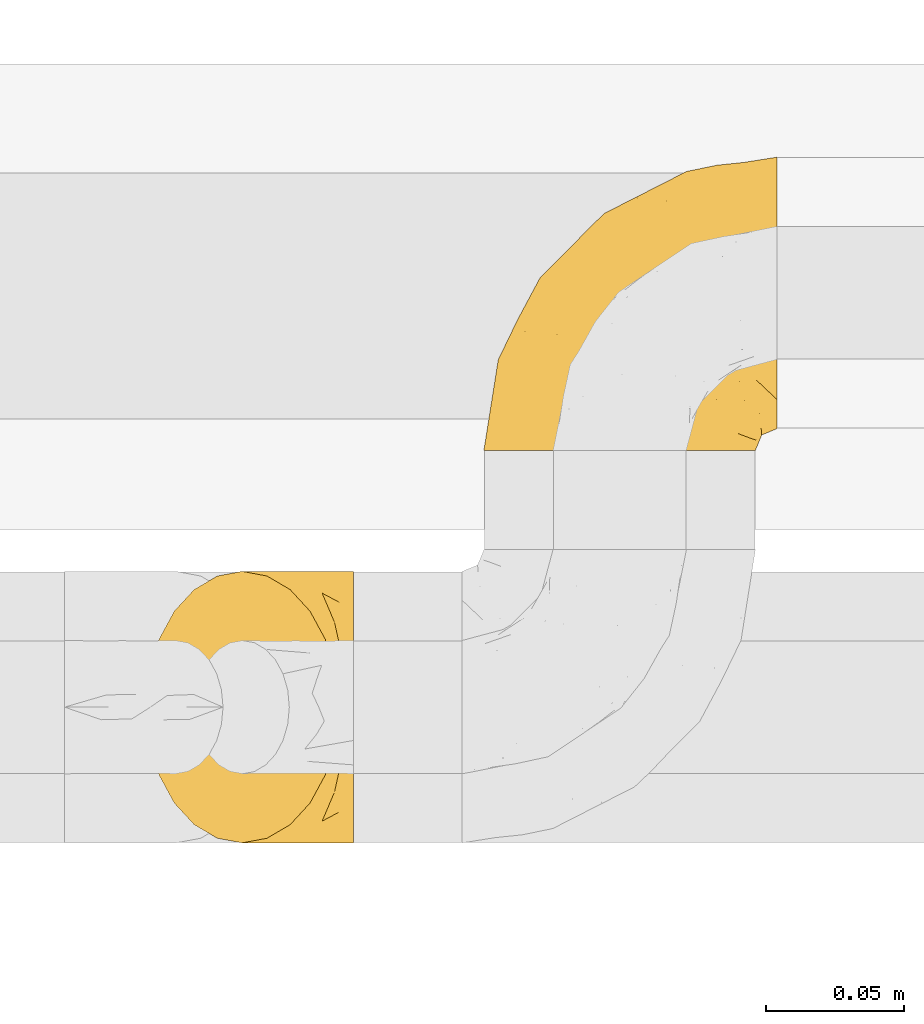
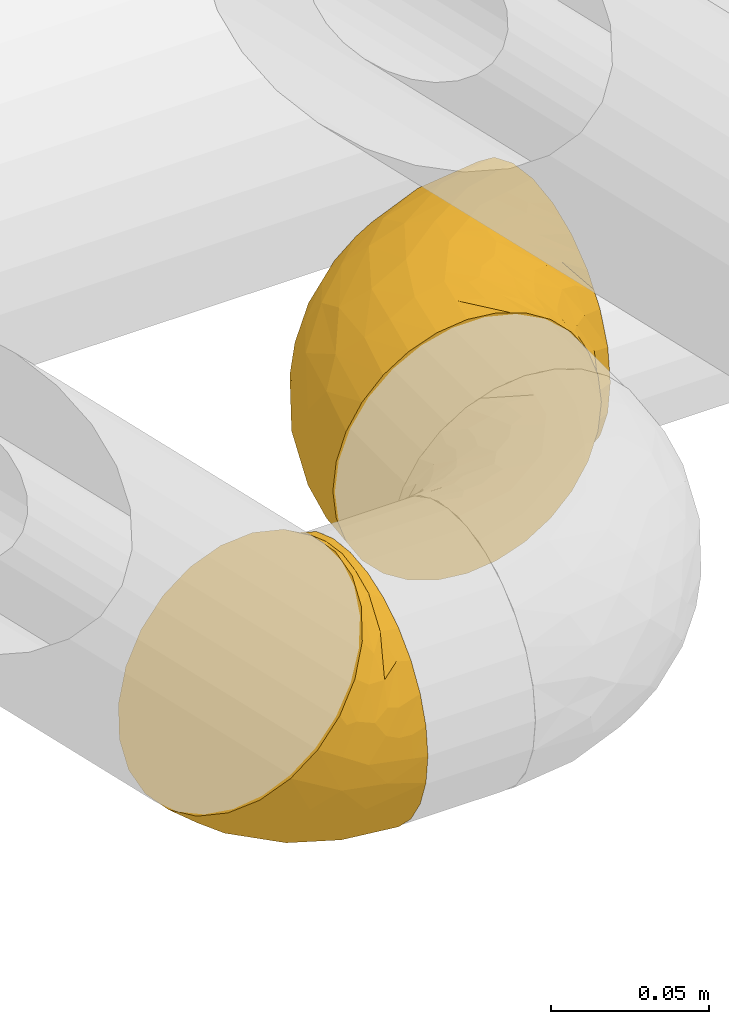
# One storey, part 30 of 93: 2 coverings.
"""IFC2X3 building model written with IfcOpenShell, lengths in millimetres."""

from ifc_helpers import new_model, entity, si_unit, converted_unit, derived_unit, direction, frame, origin, place, context, subcontext, project, spatial, faceted_brep, element, save


model = new_model("IFC2X3")

# Units and contexts
model_context = context("Model", 3, precision=0.01, world=origin(), true_north=direction((6.12303176911189e-17, 1.0)))
body_context = subcontext(model_context, "Body", "Model", "MODEL_VIEW")
ifc_project = project(units=[si_unit("LENGTHUNIT", "METRE", prefix="MILLI"), si_unit("AREAUNIT", "SQUARE_METRE"), si_unit("VOLUMEUNIT", "CUBIC_METRE"), converted_unit("PLANEANGLEUNIT", "DEGREE", entity("IfcRatioMeasure", 0.0174532925199433), si_unit("PLANEANGLEUNIT", "RADIAN"), dimensions=[0, 0, 0, 0, 0, 0, 0]), si_unit("MASSUNIT", "GRAM", prefix="KILO"), derived_unit("MASSDENSITYUNIT", [(si_unit("MASSUNIT", "GRAM", prefix="KILO"), 1), (si_unit("LENGTHUNIT", "METRE"), -3)]), derived_unit("MOMENTOFINERTIAUNIT", [(si_unit("LENGTHUNIT", "METRE"), 4)]), si_unit("TIMEUNIT", "SECOND"), si_unit("FREQUENCYUNIT", "HERTZ"), si_unit("THERMODYNAMICTEMPERATUREUNIT", "DEGREE_CELSIUS"), derived_unit("THERMALTRANSMITTANCEUNIT", [(si_unit("MASSUNIT", "GRAM", prefix="KILO"), 1), (si_unit("THERMODYNAMICTEMPERATUREUNIT", "KELVIN"), -1), (si_unit("TIMEUNIT", "SECOND"), -3)]), derived_unit("VOLUMETRICFLOWRATEUNIT", [(si_unit("LENGTHUNIT", "METRE"), 3), (si_unit("TIMEUNIT", "SECOND"), -1)]), derived_unit("MASSFLOWRATEUNIT", [(si_unit("MASSUNIT", "GRAM", prefix="KILO"), 1), (si_unit("TIMEUNIT", "SECOND"), -1)]), derived_unit("ROTATIONALFREQUENCYUNIT", [(si_unit("TIMEUNIT", "SECOND"), -1)]), si_unit("ELECTRICCURRENTUNIT", "AMPERE"), si_unit("ELECTRICVOLTAGEUNIT", "VOLT"), si_unit("POWERUNIT", "WATT"), si_unit("FORCEUNIT", "NEWTON", prefix="KILO"), si_unit("ILLUMINANCEUNIT", "LUX"), si_unit("LUMINOUSFLUXUNIT", "LUMEN"), si_unit("LUMINOUSINTENSITYUNIT", "CANDELA"), derived_unit("USERDEFINED", [(si_unit("MASSUNIT", "GRAM", prefix="KILO"), -1), (si_unit("LENGTHUNIT", "METRE"), -2), (si_unit("TIMEUNIT", "SECOND"), 3), (si_unit("LUMINOUSFLUXUNIT", "LUMEN"), 1)]), derived_unit("LINEARVELOCITYUNIT", [(si_unit("LENGTHUNIT", "METRE"), 1), (si_unit("TIMEUNIT", "SECOND"), -1)]), si_unit("PRESSUREUNIT", "PASCAL"), derived_unit("USERDEFINED", [(si_unit("LENGTHUNIT", "METRE"), -2), (si_unit("MASSUNIT", "GRAM", prefix="KILO"), 1), (si_unit("TIMEUNIT", "SECOND"), -2)]), derived_unit("LINEARFORCEUNIT", [(si_unit("MASSUNIT", "GRAM", prefix="KILO"), 1), (si_unit("LENGTHUNIT", "METRE"), 1), (si_unit("TIMEUNIT", "SECOND"), -2), (si_unit("LENGTHUNIT", "METRE"), -1)]), derived_unit("PLANARFORCEUNIT", [(si_unit("MASSUNIT", "GRAM", prefix="KILO"), 1), (si_unit("LENGTHUNIT", "METRE"), 1), (si_unit("TIMEUNIT", "SECOND"), -2), (si_unit("LENGTHUNIT", "METRE"), -2)])], contexts=[model_context])

# Site, building, storey
site_placement = place(None, origin())
site = spatial("IfcSite", under=ifc_project, at=site_placement, CompositionType="ELEMENT")
building_placement = place(site_placement, origin())
building = spatial("IfcBuilding", under=site, at=building_placement, CompositionType="ELEMENT")
storey_placement = place(building_placement, frame((0.0, 0.0, -4200.0)))
storey = spatial("IfcBuildingStorey", under=building, at=storey_placement, CompositionType="ELEMENT", Elevation=-4200.0)

# Coverings
covering_1_placement = place(storey_placement, frame((23802.3, 8802.55, 2649.25)))
element("IfcCovering", 1, at=covering_1_placement, inside=storey, Name=":ADSK_", ObjectType=":ADSK_", PredefinedType="INSULATION", context=body_context, shape_type="Brep", body=[
    faceted_brep([(50.75, 1.6, 99.9), (39.8, 1.6, 98.66), (29.41, 1.6, 95.02), (20.09, 1.6, 89.17), (12.31, 1.6, 81.38), (6.46, 1.6, 72.06), (2.83, 1.6, 61.68), (1.6, 1.6, 50.75), (2.83, 1.6, 39.8), (6.47, 1.6, 29.41), (12.32, 1.6, 20.09), (20.11, 1.6, 12.31), (29.43, 1.6, 6.46), (39.81, 1.6, 2.83), (50.75, 1.6, 1.6), (56.45, 1.6, 2.24), (61.69, 1.6, 2.83), (66.88, 1.6, 4.65), (72.08, 1.6, 6.47), (81.4, 1.6, 12.32), (89.18, 1.6, 20.11), (95.03, 1.6, 29.43), (98.66, 1.6, 39.81), (99.9, 1.6, 50.75), (98.66, 1.6, 61.69), (95.02, 1.6, 72.08), (89.17, 1.6, 81.4), (81.38, 1.6, 89.18), (72.06, 1.6, 95.03), (66.87, 1.6, 96.85), (61.68, 1.6, 98.66), (56.45, 1.6, 99.25), (53.6, 1.6, 99.57), (107.75, 11.12, 38.02), (107.75, 16.03, 26.17), (107.75, 19.94, 21.08), (107.75, 23.84, 15.99), (107.75, 28.93, 12.09), (107.75, 34.02, 8.18), (107.75, 39.95, 5.73), (107.75, 45.87, 3.27), (107.75, 52.86, 2.35), (107.75, 55.73, 1.97), (107.75, 58.6, 1.6), (107.75, 71.32, 3.27), (107.75, 83.17, 8.18), (107.75, 93.35, 15.99), (107.75, 101.16, 26.17), (107.75, 106.07, 38.02), (107.75, 107.75, 50.75), (107.75, 106.07, 63.47), (107.75, 101.16, 75.32), (107.75, 93.35, 85.5), (107.75, 83.17, 93.31), (107.75, 71.32, 98.22), (107.75, 58.6, 99.9), (107.75, 52.86, 99.14), (107.75, 45.87, 98.22), (107.75, 39.95, 95.77), (107.75, 34.02, 93.31), (107.75, 28.93, 89.4), (107.75, 23.84, 85.5), (107.75, 19.94, 80.41), (107.75, 16.03, 75.32), (107.75, 11.12, 63.47), (107.75, 9.45, 50.75), (39.38, 81.82, 59.31), (49.75, 84.02, 73.08), (57.38, 93.05, 63.72), (74.94, 102.55, 50.75), (85.97, 104.83, 58.64), (95.66, 105.83, 50.75), (67.82, 91.87, 76.74), (83.09, 101.74, 67.68), (89.16, 97.07, 78.92), (37.01, 38.45, 94.31), (43.46, 22.17, 98.76), (51.79, 42.04, 98.4), (85.58, 77.69, 94.57), (62.84, 75.76, 89.91), (62.77, 62.11, 96.32), (88.17, 66.08, 98.79), (85.93, 54.26, 99.9), (91.42, 55.35, 99.9), (96.91, 56.44, 99.9), (99.62, 56.98, 99.9), (102.33, 57.52, 99.9), (82.57, 87.84, 87.31), (32.75, 19.41, 95.61), (13.79, 48.89, 60.43), (6.77, 26.34, 65.24), (16.46, 44.55, 72.87), (55.08, 23.41, 99.9), (58.17, 28.03, 99.9), (61.26, 32.65, 99.9), (64.35, 37.28, 99.9), (67.44, 41.9, 99.9), (24.18, 20.6, 90.65), (23.37, 63.36, 63.14), (49.76, 62.21, 91.89), (9.84, 19.94, 75.25), (3.51, 13.68, 50.75), (55.75, 80.85, 82.18), (42.34, 66.53, 85.08), (37.78, 71.06, 76.93), (21.87, 63.99, 50.75), (33.61, 75.73, 50.75), (17.1, 26.77, 83.02), (51.28, 4.31, 99.9), (51.82, 7.01, 99.9), (52.9, 12.43, 99.9), (53.99, 17.92, 99.9), (28.01, 43.43, 87.13), (28.99, 56.23, 80.85), (69.9, 54.97, 99.17), (6.79, 34.4, 50.75), (72.06, 44.99, 99.9), (76.69, 48.08, 99.9), (81.31, 51.17, 99.9), (45.35, 87.47, 50.75), (34.79, 74.55, 67.61), (25.72, 60.86, 72.25), (14.33, 49.19, 50.75), (60.15, 95.01, 50.75), (62.38, 10.27, 98.69), (100.57, 48.79, 99.01), (91.06, 45.16, 98.79), (97.66, 44.99, 98.29), (97.55, 6.17, 68.51), (93.65, 7.65, 76.82), (66.85, 21.59, 98.54), (61.93, 19.96, 99.3), (101.4, 21.0, 83.57), (100.07, 27.2, 89.47), (101.36, 14.83, 75.76), (95.94, 19.7, 84.86), (96.3, 10.93, 75.89), (101.98, 9.63, 64.77), (85.88, 19.97, 90.83), (78.88, 21.13, 94.62), (82.8, 14.14, 90.37), (102.58, 30.2, 91.18), (82.88, 8.12, 88.65), (88.57, 9.93, 84.11), (88.67, 24.62, 91.75), (69.08, 11.87, 96.86), (102.19, 7.15, 50.75), (100.06, 5.32, 58.97), (70.56, 26.68, 98.37), (91.07, 13.92, 83.91), (77.56, 30.67, 97.52), (96.59, 36.65, 95.55), (86.38, 42.89, 98.76), (91.79, 34.04, 95.26), (81.71, 36.6, 98.04), (94.11, 26.41, 90.65), (76.09, 10.07, 93.51), (76.91, 15.83, 94.16), (81.44, 41.99, 99.1), (101.37, 14.83, 25.73), (94.12, 26.4, 10.84), (101.41, 21.01, 17.92), (95.96, 19.71, 16.64), (96.22, 5.72, 30.44), (66.85, 21.6, 2.95), (61.94, 19.96, 2.19), (58.17, 28.03, 1.6), (69.1, 11.87, 4.63), (88.58, 9.93, 17.39), (96.91, 56.44, 1.6), (102.33, 57.52, 1.6), (105.04, 58.06, 1.6), (82.9, 8.13, 12.86), (82.82, 14.15, 11.13), (97.66, 44.99, 3.2), (96.59, 36.65, 5.94), (100.07, 27.21, 12.02), (91.79, 34.04, 6.23), (102.58, 30.2, 10.31), (76.13, 10.06, 8.0), (76.93, 15.83, 7.34), (100.57, 48.79, 2.48), (86.38, 42.89, 2.73), (90.86, 45.38, 2.64), (52.9, 12.43, 1.6), (62.39, 10.28, 2.8), (101.98, 9.64, 36.71), (91.42, 55.35, 1.6), (85.93, 54.26, 1.6), (99.49, 6.05, 38.59), (51.82, 7.01, 1.6), (52.36, 9.72, 1.6), (61.26, 32.65, 1.6), (70.56, 26.68, 3.12), (91.09, 13.92, 17.59), (64.35, 37.28, 1.6), (77.6, 30.66, 3.98), (78.89, 21.14, 6.87), (81.71, 36.59, 3.45), (88.69, 24.6, 9.76), (53.99, 17.92, 1.6), (55.08, 23.41, 1.6), (96.31, 10.93, 25.62), (85.9, 19.97, 10.67), (81.45, 41.99, 2.39), (76.69, 48.08, 1.6), (81.31, 51.17, 1.6), (72.06, 44.99, 1.6), (67.44, 41.9, 1.6), (69.6, 55.26, 2.4), (85.97, 104.83, 42.85), (82.57, 87.84, 14.18), (63.16, 75.91, 11.56), (55.81, 80.84, 19.27), (67.81, 91.87, 24.75), (49.73, 83.98, 28.37), (32.55, 19.16, 5.95), (43.23, 22.37, 2.79), (88.17, 66.08, 2.71), (57.38, 93.05, 37.78), (83.08, 101.74, 33.81), (89.16, 97.07, 22.57), (85.58, 77.69, 6.92), (16.46, 44.55, 28.61), (6.77, 26.34, 36.24), (13.8, 48.9, 41.05), (37.71, 70.99, 24.55), (34.8, 74.55, 33.88), (36.83, 37.8, 7.11), (39.38, 81.82, 42.18), (17.12, 26.77, 18.46), (24.19, 20.6, 10.84), (28.89, 56.15, 20.69), (25.69, 60.85, 29.27), (51.77, 42.06, 3.1), (45.66, 57.03, 9.18), (23.39, 63.4, 38.38), (9.85, 19.94, 26.23), (28.11, 43.59, 14.34), (62.27, 62.61, 5.46), (42.35, 66.52, 16.39)], [[[0, 1, 2, 3, 4, 5, 6, 7, 8, 9, 10, 11, 12, 13, 14, 15, 16, 17, 18, 19, 20, 21, 22, 23, 24, 25, 26, 27, 28, 29, 30, 31, 32]], [[33, 34, 35, 36, 37, 38, 39, 40, 41, 42, 43, 44, 45, 46, 47, 48, 49, 50, 51, 52, 53, 54, 55, 56, 57, 58, 59, 60, 61, 62, 63, 64, 65]], [[66, 67, 68]], [[69, 70, 71]], [[68, 72, 73]], [[73, 72, 74]], [[75, 76, 77]], [[78, 79, 80]], [[51, 50, 73]], [[81, 82, 83, 84, 85, 86, 55]], [[52, 87, 53]], [[74, 52, 51]], [[2, 1, 88]], [[89, 90, 91]], [[77, 92, 93, 94, 95, 96]], [[55, 54, 81]], [[78, 53, 87]], [[5, 90, 6]], [[88, 76, 75]], [[97, 3, 2]], [[89, 91, 98]], [[99, 80, 79]], [[90, 5, 100]], [[74, 87, 52]], [[100, 5, 4]], [[90, 101, 6]], [[79, 102, 103]], [[102, 67, 104]], [[105, 98, 106]], [[107, 4, 3]], [[76, 0, 108, 109, 110, 111, 92]], [[107, 112, 113]], [[114, 77, 96]], [[89, 115, 90]], [[114, 96, 116, 117, 118, 82]], [[75, 97, 88]], [[119, 66, 68]], [[50, 71, 70]], [[100, 91, 90]], [[99, 77, 80]], [[102, 104, 103]], [[97, 107, 3]], [[80, 81, 78]], [[107, 97, 112]], [[68, 73, 70]], [[66, 98, 120]], [[78, 81, 54]], [[114, 81, 80]], [[53, 78, 54]], [[78, 87, 79]], [[102, 87, 72]], [[79, 103, 99]], [[4, 107, 100]], [[91, 100, 107]], [[88, 97, 2]], [[112, 97, 75]], [[99, 112, 75]], [[103, 104, 113]], [[91, 121, 98]], [[89, 105, 122, 115]], [[101, 90, 115]], [[101, 7, 6]], [[88, 1, 76]], [[0, 76, 1]], [[92, 77, 76]], [[73, 74, 51]], [[87, 74, 72]], [[81, 114, 82]], [[77, 114, 80]], [[87, 102, 79]], [[67, 102, 72]], [[68, 67, 72]], [[67, 120, 104]], [[120, 121, 104]], [[104, 121, 113]], [[121, 120, 98]], [[91, 107, 113]], [[91, 113, 121]], [[103, 113, 112]], [[106, 98, 66]], [[105, 89, 98]], [[106, 66, 119]], [[67, 66, 120]], [[68, 69, 123, 119]], [[50, 49, 71]], [[50, 70, 73]], [[112, 99, 103]], [[77, 99, 75]], [[69, 68, 70]], [[29, 124, 110]], [[84, 83, 125]], [[126, 82, 118]], [[59, 58, 127]], [[25, 128, 129]], [[130, 93, 131]], [[132, 62, 133]], [[134, 135, 136]], [[137, 65, 64]], [[64, 134, 137]], [[138, 139, 140]], [[111, 110, 124, 92]], [[134, 136, 137]], [[134, 64, 63]], [[141, 61, 60]], [[125, 58, 57]], [[142, 143, 140]], [[142, 26, 143]], [[127, 83, 82]], [[28, 124, 29]], [[108, 0, 32, 31, 30, 110, 109]], [[30, 29, 110]], [[135, 144, 138]], [[28, 145, 124]], [[57, 56, 55, 86, 85, 84]], [[146, 147, 23]], [[24, 23, 147]], [[25, 143, 26]], [[95, 94, 148]], [[24, 128, 25]], [[149, 138, 143]], [[124, 145, 131]], [[127, 58, 125]], [[150, 148, 139]], [[127, 126, 151]], [[151, 59, 127]], [[152, 151, 126]], [[153, 154, 155]], [[153, 133, 141]], [[145, 28, 27]], [[142, 156, 27]], [[157, 148, 130]], [[61, 133, 62]], [[134, 132, 135]], [[147, 128, 24]], [[65, 137, 146]], [[146, 137, 147]], [[128, 137, 136]], [[137, 128, 147]], [[128, 136, 129]], [[149, 129, 136]], [[25, 129, 143]], [[158, 152, 117]], [[152, 118, 117]], [[153, 151, 152]], [[158, 116, 154]], [[144, 150, 138]], [[153, 152, 158]], [[133, 153, 155]], [[133, 155, 132]], [[60, 151, 141]], [[135, 132, 155]], [[134, 63, 132]], [[144, 135, 155]], [[135, 138, 149]], [[155, 154, 144]], [[150, 154, 96]], [[154, 150, 144]], [[148, 94, 130]], [[82, 126, 127]], [[118, 152, 126]], [[150, 96, 95]], [[139, 148, 157]], [[150, 95, 148]], [[93, 92, 131]], [[130, 145, 156]], [[130, 94, 93]], [[84, 125, 57]], [[127, 125, 83]], [[140, 139, 157]], [[150, 139, 138]], [[140, 157, 142]], [[138, 140, 143]], [[156, 142, 157]], [[27, 26, 142]], [[130, 156, 157]], [[145, 27, 156]], [[132, 63, 62]], [[124, 131, 92]], [[130, 131, 145]], [[129, 149, 143]], [[135, 149, 136]], [[141, 133, 61]], [[60, 59, 151]], [[141, 151, 153]], [[116, 96, 154]], [[153, 158, 154]], [[158, 117, 116]], [[34, 33, 159]], [[160, 161, 162]], [[22, 21, 163]], [[164, 165, 166]], [[19, 18, 167]], [[168, 21, 20]], [[42, 41, 40, 169, 170, 171, 43]], [[172, 173, 168]], [[174, 38, 175]], [[176, 177, 178]], [[179, 164, 180]], [[40, 181, 169]], [[182, 183, 175]], [[17, 184, 185]], [[65, 146, 186]], [[187, 174, 188]], [[23, 22, 189]], [[174, 39, 38]], [[15, 14, 190, 191, 184, 16]], [[181, 40, 39]], [[192, 193, 164]], [[194, 163, 168]], [[33, 186, 159]], [[180, 173, 172]], [[195, 196, 193]], [[18, 185, 167]], [[173, 180, 197]], [[198, 199, 196]], [[200, 201, 185, 184]], [[184, 17, 16]], [[18, 17, 185]], [[202, 159, 186]], [[194, 168, 203]], [[189, 163, 202]], [[204, 205, 182]], [[187, 181, 174]], [[160, 177, 176]], [[206, 183, 182]], [[206, 182, 205]], [[201, 165, 185]], [[165, 164, 167]], [[172, 179, 180]], [[202, 194, 162]], [[176, 161, 160]], [[65, 186, 33]], [[163, 189, 22]], [[175, 177, 182]], [[174, 183, 188]], [[177, 198, 204]], [[199, 160, 162]], [[198, 207, 204]], [[175, 38, 37]], [[198, 177, 160]], [[178, 177, 175]], [[176, 35, 161]], [[34, 159, 161]], [[162, 161, 159]], [[202, 162, 159]], [[199, 162, 203]], [[196, 199, 203]], [[198, 160, 199]], [[193, 197, 180]], [[208, 198, 196]], [[188, 183, 206]], [[175, 183, 174]], [[193, 192, 195]], [[195, 208, 196]], [[197, 196, 203]], [[180, 164, 193]], [[168, 163, 21]], [[166, 165, 201]], [[166, 192, 164]], [[189, 202, 186]], [[186, 146, 189]], [[23, 189, 146]], [[174, 181, 39]], [[169, 181, 187]], [[196, 197, 193]], [[173, 203, 168]], [[203, 173, 197]], [[172, 168, 20]], [[20, 19, 172]], [[179, 172, 19]], [[19, 167, 179]], [[164, 179, 167]], [[35, 176, 36]], [[35, 34, 161]], [[185, 165, 167]], [[162, 194, 203]], [[163, 194, 202]], [[176, 178, 36]], [[37, 36, 178]], [[175, 37, 178]], [[177, 204, 182]], [[207, 198, 208]], [[207, 205, 204]], [[209, 188, 206, 205, 207, 208]], [[48, 210, 71]], [[211, 212, 213]], [[214, 213, 215]], [[216, 217, 13]], [[218, 43, 171, 170, 169, 187, 188]], [[219, 220, 214]], [[47, 46, 221]], [[210, 48, 220]], [[211, 222, 212]], [[222, 45, 44]], [[221, 220, 47]], [[47, 220, 48]], [[221, 211, 214]], [[223, 224, 225]], [[211, 46, 45]], [[226, 227, 215]], [[43, 218, 44]], [[217, 216, 228]], [[219, 215, 229]], [[14, 13, 217]], [[224, 9, 8]], [[10, 230, 11]], [[11, 231, 12]], [[232, 223, 233]], [[234, 208, 195, 192, 166, 201]], [[235, 234, 228]], [[222, 44, 218]], [[106, 229, 236]], [[224, 237, 9]], [[231, 238, 228]], [[9, 237, 10]], [[115, 224, 101]], [[239, 234, 235]], [[231, 11, 230]], [[223, 230, 237]], [[224, 8, 101]], [[223, 236, 233]], [[225, 115, 122, 105]], [[216, 12, 231]], [[209, 234, 239]], [[210, 219, 69]], [[219, 214, 215]], [[229, 119, 219]], [[209, 218, 188]], [[239, 212, 222]], [[239, 222, 218]], [[45, 222, 211]], [[235, 212, 239]], [[213, 212, 240]], [[223, 237, 224]], [[230, 10, 237]], [[238, 231, 230]], [[216, 231, 228]], [[232, 230, 223]], [[235, 238, 240]], [[115, 225, 224]], [[233, 236, 227]], [[8, 7, 101]], [[234, 209, 208]], [[218, 209, 239]], [[217, 228, 234]], [[13, 12, 216]], [[234, 201, 217]], [[217, 201, 200, 184, 191, 190, 14]], [[211, 221, 46]], [[220, 221, 214]], [[71, 210, 69]], [[71, 49, 48]], [[219, 210, 220]], [[226, 215, 213]], [[211, 213, 214]], [[226, 213, 240]], [[215, 227, 229]], [[232, 240, 238]], [[233, 227, 226]], [[232, 233, 226]], [[236, 223, 225]], [[240, 232, 226]], [[232, 238, 230]], [[225, 105, 236]], [[236, 105, 106]], [[236, 229, 227]], [[123, 69, 219, 119]], [[106, 119, 229]], [[238, 235, 228]], [[212, 235, 240]]]),
])
covering_2_placement = place(storey_placement, frame((23680.0, 8660.4, 2649.25)))
element("IfcCovering", 2, at=covering_2_placement, inside=storey, Name=":ADSK_", ObjectType=":ADSK_", PredefinedType="INSULATION", context=body_context, shape_type="Brep", body=[
    faceted_brep([(76.65, 50.75, 99.9), (76.65, 39.8, 98.66), (76.65, 29.41, 95.02), (76.65, 20.09, 89.17), (76.65, 12.31, 81.38), (76.65, 6.46, 72.06), (76.65, 2.83, 61.68), (76.65, 1.6, 50.75), (76.65, 2.83, 39.8), (76.65, 6.47, 29.41), (76.65, 12.32, 20.09), (76.65, 20.11, 12.31), (76.65, 29.43, 6.46), (76.65, 39.81, 2.83), (76.65, 50.75, 1.6), (76.65, 61.69, 2.83), (76.65, 72.08, 6.47), (76.65, 81.4, 12.32), (76.65, 89.18, 20.11), (76.65, 95.03, 29.43), (76.65, 98.66, 39.81), (76.65, 99.9, 50.75), (76.65, 98.66, 61.69), (76.65, 95.02, 72.08), (76.65, 89.17, 81.4), (76.65, 81.38, 89.18), (76.65, 72.06, 95.03), (76.65, 61.68, 98.66), (69.92, 63.47, 101.01), (66.45, 75.32, 97.54), (60.92, 85.5, 92.02), (53.73, 93.31, 84.82), (45.34, 98.22, 76.44), (42.63, 98.73, 73.72), (36.35, 99.9, 67.44), (27.35, 98.22, 58.45), (18.97, 93.31, 50.06), (11.77, 85.5, 42.87), (6.25, 75.32, 37.34), (2.78, 63.47, 33.87), (1.6, 50.75, 32.69), (2.78, 38.02, 33.87), (6.25, 26.17, 37.34), (11.77, 15.99, 42.87), (18.97, 8.18, 50.06), (27.35, 3.27, 58.45), (36.35, 1.6, 67.44), (42.63, 2.76, 73.72), (45.34, 3.27, 76.44), (49.54, 5.73, 80.63), (53.73, 8.18, 84.82), (60.92, 15.99, 92.02), (66.45, 26.17, 97.54), (69.92, 38.02, 101.01), (71.1, 50.75, 102.19), (55.78, 17.06, 17.34), (23.58, 50.75, 15.82), (15.57, 42.16, 21.86), (22.85, 21.74, 27.43), (20.19, 32.73, 21.92), (39.05, 26.38, 15.43), (27.54, 13.88, 32.91), (34.86, 40.98, 11.24), (44.58, 10.72, 28.46), (38.25, 18.26, 22.07), (55.96, 5.11, 35.39), (36.06, 6.1, 41.65), (45.71, 2.75, 47.63), (62.18, 2.16, 44.99), (54.84, 1.6, 55.08), (58.77, 25.58, 10.15), (53.8, 35.33, 6.63), (49.18, 50.75, 5.21), (61.94, 9.83, 24.81), (50.19, 1.6, 58.19), (45.54, 1.6, 61.3), (43.24, 1.6, 62.84), (40.94, 1.6, 64.37), (71.24, 1.6, 51.82), (65.82, 1.6, 52.9), (60.33, 1.6, 53.99), (72.43, 31.89, 96.93), (58.4, 3.63, 68.79), (51.68, 3.42, 71.85), (61.89, 2.64, 63.19), (64.0, 5.35, 71.74), (69.79, 19.98, 90.38), (64.24, 14.31, 87.19), (65.3, 9.44, 79.59), (47.71, 2.88, 72.23), (71.33, 2.5, 60.42), (66.54, 2.44, 60.92), (73.13, 41.56, 99.77), (58.83, 8.24, 80.78), (71.54, 12.78, 82.47), (68.29, 5.31, 70.43), (73.65, 50.75, 100.49), (64.24, 87.18, 87.19), (69.79, 81.5, 90.39), (58.83, 93.25, 80.78), (73.13, 59.93, 99.78), (72.43, 69.59, 96.94), (71.24, 99.9, 51.82), (65.31, 92.03, 79.62), (40.94, 99.9, 64.37), (46.81, 99.1, 69.89), (71.54, 88.7, 82.49), (51.68, 98.07, 71.85), (54.84, 99.9, 55.08), (58.41, 97.86, 68.8), (61.89, 98.85, 63.2), (50.19, 99.9, 58.19), (68.29, 96.17, 70.45), (65.82, 99.9, 52.9), (71.32, 98.99, 60.41), (66.55, 99.04, 60.94), (64.0, 96.14, 71.76), (60.33, 99.9, 53.99), (45.54, 99.9, 61.3), (55.96, 96.38, 35.4), (45.71, 98.74, 47.64), (55.78, 84.45, 17.35), (36.06, 95.4, 41.67), (44.59, 90.78, 28.47), (23.23, 60.07, 17.06), (20.2, 68.76, 21.92), (22.84, 79.75, 27.43), (39.05, 75.13, 15.44), (62.18, 99.34, 44.99), (27.54, 87.61, 32.91), (61.95, 91.67, 24.82), (35.76, 65.98, 12.42), (53.79, 66.17, 6.63), (58.77, 75.92, 10.16), (38.25, 83.22, 22.07)], [[[0, 1, 2, 3, 4, 5, 6, 7, 8, 9, 10, 11, 12, 13, 14, 15, 16, 17, 18, 19, 20, 21, 22, 23, 24, 25, 26, 27]], [[28, 29, 30, 31, 32, 33, 34, 35, 36, 37, 38, 39, 40, 41, 42, 43, 44, 45, 46, 47, 48, 49, 50, 51, 52, 53, 54]], [[10, 55, 11]], [[40, 56, 57]], [[42, 58, 43]], [[59, 60, 58]], [[61, 44, 43]], [[60, 59, 62]], [[63, 61, 64]], [[63, 65, 66]], [[67, 46, 45]], [[66, 67, 45]], [[42, 41, 59]], [[67, 68, 69]], [[58, 61, 43]], [[70, 60, 71]], [[71, 62, 72]], [[72, 13, 71]], [[55, 70, 11]], [[12, 70, 71]], [[59, 58, 42]], [[14, 13, 72]], [[73, 55, 10]], [[67, 69, 74, 75, 76, 77, 46]], [[41, 57, 59]], [[68, 7, 78, 79, 80, 69]], [[9, 8, 65]], [[73, 65, 63]], [[45, 44, 66]], [[67, 66, 65]], [[9, 73, 10]], [[57, 62, 59]], [[68, 65, 8]], [[12, 71, 13]], [[60, 55, 64]], [[66, 44, 61]], [[64, 61, 58]], [[61, 63, 66]], [[60, 64, 58]], [[63, 64, 55]], [[65, 73, 9]], [[55, 73, 63]], [[65, 68, 67]], [[7, 68, 8]], [[11, 70, 12]], [[55, 60, 70]], [[40, 57, 41]], [[62, 57, 56]], [[72, 62, 56]], [[62, 71, 60]], [[52, 81, 53]], [[82, 83, 74]], [[84, 85, 82]], [[86, 87, 88]], [[77, 89, 48]], [[87, 52, 51]], [[90, 5, 91]], [[92, 1, 0]], [[86, 2, 81]], [[54, 53, 92]], [[52, 86, 81]], [[93, 51, 50]], [[87, 51, 93]], [[83, 93, 50]], [[94, 95, 4]], [[5, 4, 95]], [[5, 95, 91]], [[7, 6, 78]], [[94, 88, 85]], [[86, 94, 3]], [[48, 47, 46, 77]], [[96, 92, 0]], [[80, 91, 84]], [[2, 1, 81]], [[3, 2, 86]], [[90, 78, 6]], [[1, 92, 81]], [[94, 86, 88]], [[82, 93, 83]], [[3, 94, 4]], [[80, 84, 69]], [[82, 88, 93]], [[49, 48, 89]], [[69, 82, 74]], [[83, 75, 74]], [[88, 87, 93]], [[52, 87, 86]], [[91, 80, 79]], [[91, 79, 90]], [[84, 91, 95]], [[85, 84, 95]], [[69, 84, 82]], [[78, 90, 79]], [[5, 90, 6]], [[94, 85, 95]], [[82, 85, 88]], [[54, 92, 96]], [[81, 92, 53]], [[83, 89, 75]], [[77, 76, 75, 89]], [[83, 49, 89]], [[83, 50, 49]], [[97, 29, 98]], [[30, 99, 31]], [[100, 101, 28]], [[22, 21, 102]], [[103, 99, 97]], [[101, 29, 28]], [[104, 33, 105]], [[98, 106, 103]], [[107, 31, 99]], [[97, 99, 30]], [[108, 109, 110]], [[26, 98, 101]], [[54, 96, 100]], [[109, 111, 107]], [[0, 27, 100]], [[112, 106, 24]], [[101, 27, 26]], [[102, 113, 114]], [[105, 31, 107]], [[25, 98, 26]], [[24, 106, 25]], [[112, 24, 23]], [[106, 98, 25]], [[23, 22, 114]], [[112, 115, 110]], [[113, 115, 114]], [[29, 101, 98]], [[112, 116, 106]], [[29, 97, 30]], [[96, 0, 100]], [[115, 113, 117]], [[103, 109, 99]], [[109, 107, 99]], [[105, 107, 118]], [[111, 109, 108]], [[111, 118, 107]], [[103, 97, 98]], [[110, 116, 112]], [[110, 115, 117]], [[23, 115, 112]], [[108, 110, 117]], [[116, 109, 103]], [[23, 114, 115]], [[102, 114, 22]], [[109, 116, 110]], [[106, 116, 103]], [[104, 34, 33]], [[33, 32, 105]], [[101, 100, 27]], [[54, 100, 28]], [[104, 105, 118]], [[31, 105, 32]], [[20, 19, 119]], [[35, 34, 120]], [[120, 34, 104, 118, 111, 108]], [[121, 18, 17]], [[36, 35, 122]], [[122, 119, 123]], [[39, 124, 40]], [[125, 126, 127]], [[125, 39, 38]], [[128, 120, 108]], [[129, 36, 122]], [[38, 126, 125]], [[129, 126, 37]], [[37, 126, 38]], [[120, 128, 119]], [[35, 120, 122]], [[119, 19, 130]], [[131, 127, 132]], [[130, 19, 18]], [[133, 17, 16]], [[134, 127, 126]], [[123, 130, 121]], [[125, 127, 131]], [[16, 132, 133]], [[15, 14, 72]], [[72, 56, 124]], [[15, 72, 132]], [[133, 132, 127]], [[123, 129, 122]], [[15, 132, 16]], [[119, 122, 120]], [[128, 21, 20]], [[39, 125, 124]], [[126, 129, 134]], [[36, 129, 37]], [[134, 123, 121]], [[123, 134, 129]], [[127, 134, 121]], [[121, 130, 18]], [[119, 130, 123]], [[128, 108, 117, 113, 102, 21]], [[119, 128, 20]], [[127, 121, 133]], [[17, 133, 121]], [[72, 131, 132]], [[124, 125, 131]], [[72, 124, 131]], [[124, 56, 40]]]),
])

save(model, "model.ifc")
